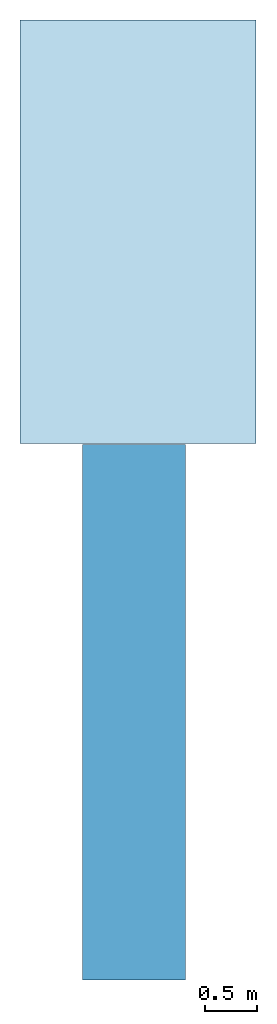
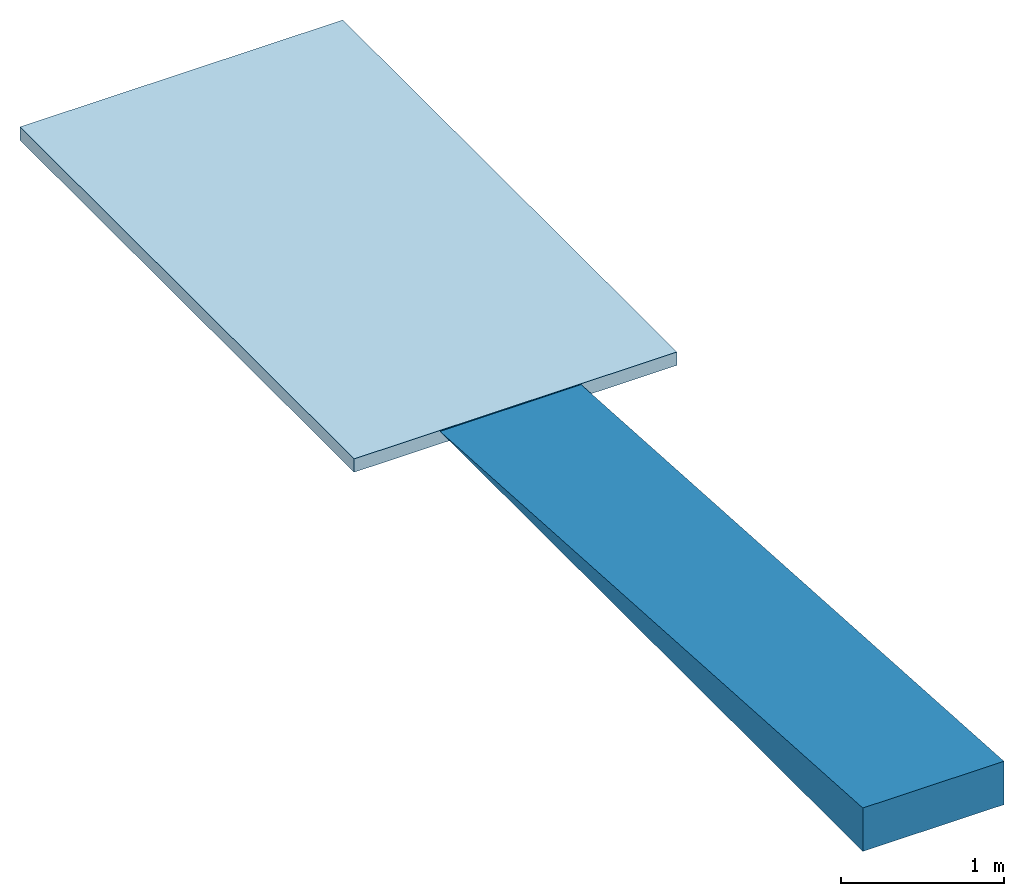
# One storey: 1 ramp flight, 1 slab, 1 element without a shape of its own.
"""IFC2X3 building model written with IfcOpenShell, lengths in metres."""

from ifc_helpers import new_model, entity, si_unit, converted_unit, derived_unit, direction, frame, origin, place, context, subcontext, project, spatial, polyline, outline, extrude, material, layer, layer_set, layer_usage, type_object, element, aggregate, save


model = new_model("IFC2X3")

# Units and contexts
model_context = context("Model", 3, precision=1e-05, world=origin(), true_north=direction((6.123031769111886e-17, 1.0)))
body_context = subcontext(model_context, "Body", "Model", "MODEL_VIEW")
ifc_project = project(units=[si_unit("LENGTHUNIT", "METRE"), si_unit("AREAUNIT", "SQUARE_METRE"), si_unit("VOLUMEUNIT", "CUBIC_METRE"), converted_unit("PLANEANGLEUNIT", "DEGREE", entity("IfcRatioMeasure", 0.017453292519943278), si_unit("PLANEANGLEUNIT", "RADIAN"), dimensions=[0, 0, 0, 0, 0, 0, 0]), si_unit("MASSUNIT", "GRAM", prefix="KILO"), derived_unit("MASSDENSITYUNIT", [(si_unit("MASSUNIT", "GRAM", prefix="KILO"), 1), (si_unit("LENGTHUNIT", "METRE"), -3)]), derived_unit("IONCONCENTRATIONUNIT", [(si_unit("MASSUNIT", "GRAM", prefix="KILO"), 1), (si_unit("LENGTHUNIT", "METRE"), -3)]), derived_unit("MOMENTOFINERTIAUNIT", [(si_unit("LENGTHUNIT", "METRE"), 4)]), si_unit("TIMEUNIT", "SECOND"), si_unit("FREQUENCYUNIT", "HERTZ"), si_unit("THERMODYNAMICTEMPERATUREUNIT", "DEGREE_CELSIUS"), derived_unit("THERMALTRANSMITTANCEUNIT", [(si_unit("MASSUNIT", "GRAM", prefix="KILO"), 1), (si_unit("THERMODYNAMICTEMPERATUREUNIT", "KELVIN"), -1), (si_unit("TIMEUNIT", "SECOND"), -3)]), derived_unit("THERMALCONDUCTANCEUNIT", [(si_unit("MASSUNIT", "GRAM", prefix="KILO"), 1), (si_unit("THERMODYNAMICTEMPERATUREUNIT", "KELVIN"), -1), (si_unit("TIMEUNIT", "SECOND"), -3), (si_unit("LENGTHUNIT", "METRE"), 1)]), derived_unit("VOLUMETRICFLOWRATEUNIT", [(si_unit("LENGTHUNIT", "METRE"), 3), (si_unit("TIMEUNIT", "SECOND"), -1)]), derived_unit("MASSFLOWRATEUNIT", [(si_unit("MASSUNIT", "GRAM", prefix="KILO"), 1), (si_unit("TIMEUNIT", "SECOND"), -1)]), derived_unit("ROTATIONALFREQUENCYUNIT", [(si_unit("TIMEUNIT", "SECOND"), -1)]), si_unit("ELECTRICCURRENTUNIT", "AMPERE"), si_unit("ELECTRICVOLTAGEUNIT", "VOLT"), si_unit("POWERUNIT", "WATT"), si_unit("FORCEUNIT", "NEWTON", prefix="KILO"), si_unit("ILLUMINANCEUNIT", "LUX"), si_unit("LUMINOUSFLUXUNIT", "LUMEN"), si_unit("LUMINOUSINTENSITYUNIT", "CANDELA"), derived_unit("USERDEFINED", [(si_unit("MASSUNIT", "GRAM", prefix="KILO"), -1), (si_unit("LENGTHUNIT", "METRE"), -2), (si_unit("TIMEUNIT", "SECOND"), 3), (si_unit("LUMINOUSFLUXUNIT", "LUMEN"), 1)]), derived_unit("USERDEFINED", [(si_unit("MASSUNIT", "GRAM", prefix="KILO"), 1), (si_unit("TIMEUNIT", "SECOND"), -3), (si_unit("LENGTHUNIT", "METRE"), 3), (si_unit("ELECTRICCURRENTUNIT", "AMPERE"), -2)]), derived_unit("SOUNDPOWERUNIT", [(si_unit("MASSUNIT", "GRAM", prefix="KILO"), 1), (si_unit("TIMEUNIT", "SECOND"), -3), (si_unit("LENGTHUNIT", "METRE"), 2)]), derived_unit("SOUNDPRESSUREUNIT", [(si_unit("MASSUNIT", "GRAM", prefix="KILO"), 1), (si_unit("LENGTHUNIT", "METRE"), -1), (si_unit("TIMEUNIT", "SECOND"), -2)]), derived_unit("LINEARVELOCITYUNIT", [(si_unit("LENGTHUNIT", "METRE"), 1), (si_unit("TIMEUNIT", "SECOND"), -1)]), si_unit("PRESSUREUNIT", "PASCAL"), derived_unit("USERDEFINED", [(si_unit("MASSUNIT", "GRAM", prefix="KILO"), 1), (si_unit("LENGTHUNIT", "METRE"), -2), (si_unit("TIMEUNIT", "SECOND"), -2)]), derived_unit("LINEARFORCEUNIT", [(si_unit("MASSUNIT", "GRAM", prefix="KILO"), 1), (si_unit("TIMEUNIT", "SECOND"), -2)]), derived_unit("PLANARFORCEUNIT", [(si_unit("MASSUNIT", "GRAM", prefix="KILO"), 1), (si_unit("LENGTHUNIT", "METRE"), -1), (si_unit("TIMEUNIT", "SECOND"), -2)]), derived_unit("SPECIFICHEATCAPACITYUNIT", [(si_unit("THERMODYNAMICTEMPERATUREUNIT", "KELVIN"), -1), (si_unit("LENGTHUNIT", "METRE"), 2), (si_unit("TIMEUNIT", "SECOND"), -2)]), derived_unit("HEATINGVALUEUNIT", [(si_unit("LENGTHUNIT", "METRE"), 2), (si_unit("TIMEUNIT", "SECOND"), -2)]), derived_unit("VAPORPERMEABILITYUNIT", [(si_unit("LENGTHUNIT", "METRE"), -1), (si_unit("TIMEUNIT", "SECOND"), 1)]), derived_unit("DYNAMICVISCOSITYUNIT", [(si_unit("MASSUNIT", "GRAM", prefix="KILO"), 1), (si_unit("TIMEUNIT", "SECOND"), -1), (si_unit("LENGTHUNIT", "METRE"), -1)]), derived_unit("THERMALEXPANSIONCOEFFICIENTUNIT", [(si_unit("THERMODYNAMICTEMPERATUREUNIT", "KELVIN"), -1)]), derived_unit("MODULUSOFELASTICITYUNIT", [(si_unit("MASSUNIT", "GRAM", prefix="KILO"), 1), (si_unit("LENGTHUNIT", "METRE"), -1), (si_unit("TIMEUNIT", "SECOND"), -2)]), derived_unit("ISOTHERMALMOISTURECAPACITYUNIT", [(si_unit("LENGTHUNIT", "METRE"), 3), (si_unit("MASSUNIT", "GRAM", prefix="KILO"), -1)]), derived_unit("MOISTUREDIFFUSIVITYUNIT", [(si_unit("TIMEUNIT", "SECOND"), -1), (si_unit("LENGTHUNIT", "METRE"), 2)])], contexts=[model_context])

# Site, building, storey
site_placement = place(None, frame((83.18260837531514, 5.722313863433043, -0.3219974716737357), z_axis=(0.0, 0.0, 1.0), x_axis=(0.31599863684750407, -0.9487596436982969, 0.0)))
site = spatial("IfcSite", under=ifc_project, at=site_placement, CompositionType="ELEMENT")
building_placement = place(site_placement, origin())
building = spatial("IfcBuilding", under=site, at=building_placement, CompositionType="ELEMENT")
storey_placement = place(building_placement, frame((0.0, 0.0, -3.3830025283262644)))
storey = spatial("IfcBuildingStorey", under=building, at=storey_placement, Name="-1 open offices (ramp)", CompositionType="ELEMENT", Elevation=-3.3830025283262644)

# Slab
ifc_material_1 = material()
ifc_layer_1 = layer(ifc_material_1, 0.01)
ifc_material_2 = material()
ifc_layer_2 = layer(ifc_material_2, 0.09)
ifc_layer_set = layer_set([ifc_layer_1, ifc_layer_2], Name="Floor:Floor Ramp")
ifc_layer_usage = layer_usage(ifc_layer_set, "AXIS3", "POSITIVE", 0.0)
slab_type = type_object("IfcSlabType", Name="Floor:Floor Ramp", PredefinedType="FLOOR", material=ifc_layer_set)
slab_placement = place(storey_placement, origin())
element("IfcSlab", 1, at=slab_placement, inside=storey, type_object=slab_type, material=ifc_layer_usage, Name="Floor:Floor Ramp", ObjectType="Floor:Floor Ramp", PredefinedType="FLOOR", context=body_context, shape_type="SweptSolid", body=[
    extrude(outline(polyline([(-1.1430480372983527, -2.0496980651522336), (1.1430043563873702, -2.049698065152233), (1.1430043563873615, 2.049673707310592), (-1.142960675476377, 2.0497224229938795), (-1.1430480372983527, -2.0496980651522336)])), frame((-9.908681246140143, -59.03807525873766, 0.0), z_axis=(0.0, 0.0, -1.0), x_axis=(-0.3160004567826911, -0.9487590375396329, 0.0)), (0.0, 0.0, 1.0), 0.1),
])

# Ramp, ramp flight
ramp_placement = place(storey_placement, origin())
ramp = element("IfcRamp", 2, at=ramp_placement, inside=storey, Name="Ramp:Standard", ObjectType="Ramp:Standard", ShapeType="NOTDEFINED")
ifc_material_3 = material()
ramp_flight_placement = place(ramp_placement, origin())
ramp_flight = element("IfcRampFlight", 3, at=ramp_flight_placement, material=ifc_material_3, Name="Ramp:Standard:1", ObjectType="Ramp:Standard", context=body_context, shape_type="SweptSolid", body=[
    extrude(outline(polyline([(-0.21666666666666448, -1.7289742448711873), (0.10833333333333581, -1.7289742448711873), (0.1083333333333276, 3.457948489742374), (-0.21666666666666448, -1.7289742448711873)])), frame((-4.846114449401264, -61.293627754222975, 0.10833333333333307), z_axis=(0.31598023792188223, 0.9487657715383869, 0.0), x_axis=(0.0, 0.0, -1.0)), (0.0, 0.0, 1.0), 1.000000000000009),
])
aggregate(ramp, [ramp_flight])

save(model, "model.ifc")
